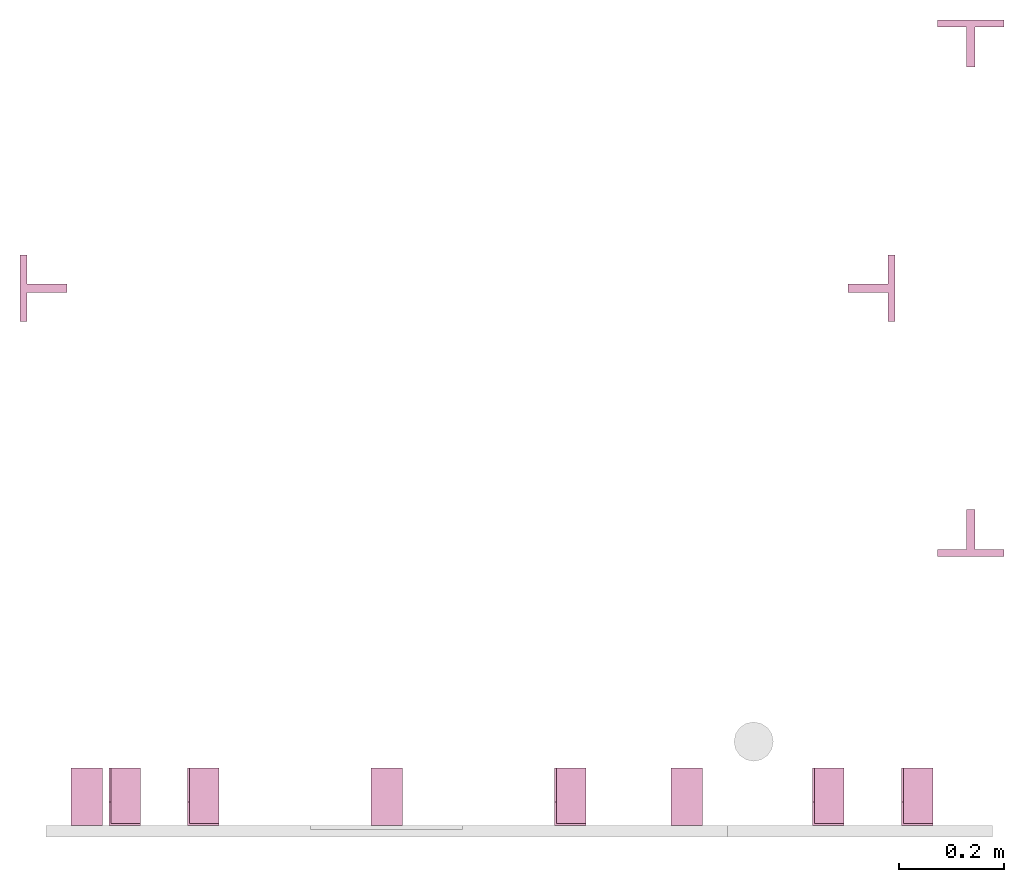
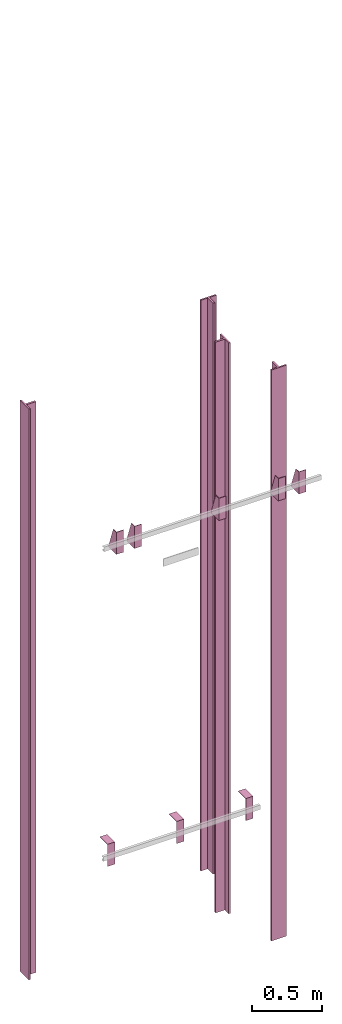
# One storey, part 3 of 3: 12 transport elements.
"""IFC4 building model written with IfcOpenShell, lengths in millimetres."""

from ifc_helpers import new_model, entity, si_unit, converted_unit, frame, origin_with_axes, place, context, subcontext, project, spatial, faceted_brep, element, save


model = new_model("IFC4")

# Units and contexts
context_of_model = context(None, 3, precision=0.01, world=origin_with_axes())
sub_context_1 = subcontext(context_of_model, None, None, "MODEL_VIEW")
sub_context_2 = subcontext(context_of_model, None, None, "MODEL_VIEW")
sub_context_3 = subcontext(context_of_model, None, None, "MODEL_VIEW")
sub_context_4 = subcontext(context_of_model, None, None, "MODEL_VIEW")
sub_context_5 = subcontext(context_of_model, None, None, "MODEL_VIEW")
sub_context_6 = subcontext(context_of_model, None, None, "MODEL_VIEW")
sub_context_7 = subcontext(context_of_model, None, None, "MODEL_VIEW")
sub_context_8 = subcontext(context_of_model, None, None, "MODEL_VIEW")
sub_context_9 = subcontext(context_of_model, None, None, "MODEL_VIEW")
sub_context_10 = subcontext(context_of_model, None, None, "MODEL_VIEW")
sub_context_11 = subcontext(context_of_model, None, None, "MODEL_VIEW")
sub_context_12 = subcontext(context_of_model, None, None, "MODEL_VIEW")
ifc_project = project(units=[converted_unit("PLANEANGLEUNIT", "degree", entity("IfcPlaneAngleMeasure", 0.017453292519943), si_unit("PLANEANGLEUNIT", "RADIAN"), dimensions=[0, 0, 0, 0, 0, 0, 0]), si_unit("LENGTHUNIT", "METRE", prefix="MILLI"), si_unit("MASSUNIT", "GRAM", prefix="KILO"), converted_unit("TIMEUNIT", "year", entity("IfcTimeMeasure", 31557600.0), si_unit("TIMEUNIT", "SECOND"), dimensions=[0, 0, 1, 0, 0, 0, 0]), si_unit("THERMODYNAMICTEMPERATUREUNIT", "DEGREE_CELSIUS"), si_unit("AREAUNIT", "SQUARE_METRE"), si_unit("FORCEUNIT", "NEWTON"), si_unit("VOLUMEUNIT", "CUBIC_METRE"), si_unit("PRESSUREUNIT", "PASCAL"), si_unit("SOLIDANGLEUNIT", "STERADIAN")], contexts=[context_of_model])

# Site, building, storey
site = spatial("IfcSite", under=ifc_project)
building = spatial("IfcBuilding", under=site, Name="Document")
placement = place(None, origin_with_axes())
storey_placement = place(placement, frame((0.0, 0.0, -14620.0), z_axis=(0.0, 0.0, 1.0), x_axis=(1.0, 0.0, 0.0)))
storey = spatial("IfcBuildingStorey", under=building, at=storey_placement, Name="P4", Elevation=-14620.0)

# Transport elements
transport_element_1_placement = place(storey_placement, frame((1879.0, 558.5, 733.0), z_axis=(0.0, -1.0, 0.0), x_axis=(0.0, 0.0, -1.0)))
element("IfcTransportElement", 1, at=transport_element_1_placement, inside=storey, ObjectType="Guide Rail", PredefinedType="ELEVATOR", context=sub_context_1, shape_type="Brep", body=[
    faceted_brep([(2347.5, -63.5, 45.0), (2347.5, 63.5, 45.0), (2347.5, 63.5, 44.0), (2347.5, -63.5, 44.0), (2500.0, -63.5, 45.0), (2500.0, -63.5, 44.0), (2500.0, 63.5, 44.0), (2500.0, 63.5, 45.0)], [[[0, 1, 2, 3]], [[4, 5, 6, 7]], [[0, 3, 5, 4]], [[3, 2, 6, 5]], [[2, 1, 7, 6]], [[1, 0, 4, 7]]]),
    faceted_brep([(-2500.0, -63.5, 45.0), (-2500.0, 63.5, 45.0), (-2500.0, 63.5, 44.0), (-2500.0, -63.5, 44.0), (-2347.5, -63.5, 45.0), (-2347.5, -63.5, 44.0), (-2347.5, 63.5, 44.0), (-2347.5, 63.5, 45.0)], [[[0, 1, 2, 3]], [[4, 5, 6, 7]], [[0, 3, 5, 4]], [[3, 2, 6, 5]], [[2, 1, 7, 6]], [[1, 0, 4, 7]]]),
    faceted_brep([(-2500.0, -63.5, 44.5), (-2500.0, -63.5, 31.79998779296875), (2500.0, -63.5, 31.79998779296875), (2500.0, -63.5, 44.5), (-2500.0, -7.93994140625, 31.79998779296875), (-2500.0, -7.93994140625, -44.5), (2500.0, -7.93994140625, -44.5), (2500.0, -7.93994140625, 31.79998779296875), (2500.0, 7.93994140625, -44.5), (-2500.0, 7.93994140625, -44.5), (-2500.0, 7.93994140625, 31.79998779296875), (2500.0, 7.93994140625, 31.79998779296875), (2500.0, 63.5, 31.79998779296875), (-2500.0, 63.5, 31.79998779296875), (-2500.0, 63.5, 44.5), (2500.0, 63.5, 44.5)], [[[0, 1, 2, 3]], [[4, 5, 6, 7]], [[8, 9, 10, 11]], [[12, 13, 14, 15]], [[15, 14, 0, 3]], [[1, 4, 7, 2]], [[10, 13, 12, 11]], [[5, 9, 8, 6]], [[2, 7, 6, 8, 11, 12, 15, 3]], [[14, 13, 10, 9, 5, 4, 1, 0]]]),
])
transport_element_2_placement = place(storey_placement, frame((1879.0, 1491.5, 733.0), z_axis=(0.0, 1.0, 0.0), x_axis=(0.0, 0.0, 1.0)))
element("IfcTransportElement", 2, at=transport_element_2_placement, inside=storey, ObjectType="Guide Rail", PredefinedType="ELEVATOR", context=sub_context_2, shape_type="Brep", body=[
    faceted_brep([(-2500.0, -63.5, 45.0), (-2500.0, 63.5, 45.0), (-2500.0, 63.5, 44.0), (-2500.0, -63.5, 44.0), (-2347.5, -63.5, 45.0), (-2347.5, -63.5, 44.0), (-2347.5, 63.5, 44.0), (-2347.5, 63.5, 45.0)], [[[0, 1, 2, 3]], [[4, 5, 6, 7]], [[0, 3, 5, 4]], [[3, 2, 6, 5]], [[2, 1, 7, 6]], [[1, 0, 4, 7]]]),
    faceted_brep([(2347.5, -63.5, 45.0), (2347.5, 63.5, 45.0), (2347.5, 63.5, 44.0), (2347.5, -63.5, 44.0), (2500.0, -63.5, 45.0), (2500.0, -63.5, 44.0), (2500.0, 63.5, 44.0), (2500.0, 63.5, 45.0)], [[[0, 1, 2, 3]], [[4, 5, 6, 7]], [[0, 3, 5, 4]], [[3, 2, 6, 5]], [[2, 1, 7, 6]], [[1, 0, 4, 7]]]),
    faceted_brep([(2500.0, -63.5, 31.800048828125), (2500.0, -63.5, 44.5), (-2500.0, -63.5, 44.5), (-2500.0, -63.5, 31.800048828125), (2500.0, -7.93994140625, -44.5), (2500.0, -7.93994140625, 31.800048828125), (-2500.0, -7.93994140625, 31.800048828125), (-2500.0, -7.93994140625, -44.5), (-2500.0, 7.93994140625, 31.800048828125), (2500.0, 7.93994140625, 31.800048828125), (2500.0, 7.93994140625, -44.5), (-2500.0, 7.93994140625, -44.5), (-2500.0, 63.5, 44.5), (2500.0, 63.5, 44.5), (2500.0, 63.5, 31.800048828125), (-2500.0, 63.5, 31.800048828125)], [[[0, 1, 2, 3]], [[4, 5, 6, 7]], [[8, 9, 10, 11]], [[12, 13, 14, 15]], [[6, 5, 0, 3]], [[1, 13, 12, 2]], [[11, 10, 4, 7]], [[9, 8, 15, 14]], [[2, 12, 15, 8, 11, 7, 6, 3]], [[5, 4, 10, 9, 14, 13, 1, 0]]]),
])
transport_element_3_placement = place(storey_placement, frame((110.5, 1025.0, 733.0), z_axis=(-1.0, 0.0, 0.0), x_axis=(0.0, 0.0, -1.0)))
element("IfcTransportElement", 3, at=transport_element_3_placement, inside=storey, ObjectType="Guide Rail", PredefinedType="ELEVATOR", context=sub_context_3, shape_type="Brep", body=[
    faceted_brep([(-2500.0, -63.5, 45.0), (-2500.0, 63.5, 45.0), (-2500.0, 63.5, 44.0), (-2500.0, -63.5, 44.0), (-2347.5, -63.5, 45.0), (-2347.5, -63.5, 44.0), (-2347.5, 63.5, 44.0), (-2347.5, 63.5, 45.0)], [[[0, 1, 2, 3]], [[4, 5, 6, 7]], [[0, 3, 5, 4]], [[3, 2, 6, 5]], [[2, 1, 7, 6]], [[1, 0, 4, 7]]]),
    faceted_brep([(2347.5, -63.5, 45.0), (2347.5, 63.5, 45.0), (2347.5, 63.5, 44.0), (2347.5, -63.5, 44.0), (2500.0, -63.5, 45.0), (2500.0, -63.5, 44.0), (2500.0, 63.5, 44.0), (2500.0, 63.5, 45.0)], [[[0, 1, 2, 3]], [[4, 5, 6, 7]], [[0, 3, 5, 4]], [[3, 2, 6, 5]], [[2, 1, 7, 6]], [[1, 0, 4, 7]]]),
    faceted_brep([(-2500.0, 63.5, 44.5), (-2500.0, -63.5, 44.5), (2500.0, -63.5, 44.5), (2500.0, 63.5, 44.5), (2500.0, 7.94000244140625, 31.800003051757812), (-2500.0, 7.94000244140625, 31.800003051757812), (-2500.0, 63.5, 31.79998779296875), (2500.0, 63.5, 31.79998779296875), (2500.0, -63.5, 31.79998779296875), (-2500.0, -63.5, 31.79998779296875), (-2500.0, -7.93994140625, 31.79998779296875), (2500.0, -7.93994140625, 31.79998779296875), (2500.0, -7.93994140625, -44.5), (-2500.0, -7.93994140625, -44.5), (-2500.0, 7.94000244140625, -44.5), (2500.0, 7.94000244140625, -44.5)], [[[0, 1, 2, 3]], [[4, 5, 6, 7]], [[8, 9, 10, 11]], [[12, 13, 14, 15]], [[7, 6, 0, 3]], [[15, 14, 5, 4]], [[10, 13, 12, 11]], [[1, 9, 8, 2]], [[2, 8, 11, 12, 15, 4, 7, 3]], [[6, 5, 14, 13, 10, 9, 1, 0]]]),
])
transport_element_4_placement = place(storey_placement, frame((1689.5, 1025.0, 733.0), z_axis=(1.0, 0.0, 0.0), x_axis=(0.0, 0.0, 1.0)))
element("IfcTransportElement", 4, at=transport_element_4_placement, inside=storey, ObjectType="Guide Rail", PredefinedType="ELEVATOR", context=sub_context_4, shape_type="Brep", body=[
    faceted_brep([(2347.5, -63.5, 45.0), (2347.5, 63.5, 45.0), (2347.5, 63.5, 44.0), (2347.5, -63.5, 44.0), (2500.0, -63.5, 45.0), (2500.0, -63.5, 44.0), (2500.0, 63.5, 44.0), (2500.0, 63.5, 45.0)], [[[0, 1, 2, 3]], [[4, 5, 6, 7]], [[0, 3, 5, 4]], [[3, 2, 6, 5]], [[2, 1, 7, 6]], [[1, 0, 4, 7]]]),
    faceted_brep([(-2500.0, -63.5, 45.0), (-2500.0, 63.5, 45.0), (-2500.0, 63.5, 44.0), (-2500.0, -63.5, 44.0), (-2347.5, -63.5, 45.0), (-2347.5, -63.5, 44.0), (-2347.5, 63.5, 44.0), (-2347.5, 63.5, 45.0)], [[[0, 1, 2, 3]], [[4, 5, 6, 7]], [[0, 3, 5, 4]], [[3, 2, 6, 5]], [[2, 1, 7, 6]], [[1, 0, 4, 7]]]),
    faceted_brep([(2500.0, 7.94000244140625, -44.5), (2500.0, -7.93994140625, -44.5), (-2500.0, -7.93994140625, -44.5), (-2500.0, 7.94000244140625, -44.5), (2500.0, 63.5, 31.800048828125), (2500.0, 7.94000244140625, 31.800048828125), (-2500.0, 7.94000244140625, 31.800048828125), (-2500.0, 63.5, 31.800048828125), (-2500.0, -63.5, 44.5), (2500.0, -63.5, 44.5), (2500.0, 63.5, 44.5), (-2500.0, 63.5, 44.5), (2500.0, -7.93994140625, 31.800048828125), (2500.0, -63.5, 31.800048828125), (-2500.0, -63.5, 31.800048828125), (-2500.0, -7.93994140625, 31.800048828125)], [[[0, 1, 2, 3]], [[4, 5, 6, 7]], [[8, 9, 10, 11]], [[12, 13, 14, 15]], [[6, 5, 0, 3]], [[1, 12, 15, 2]], [[11, 10, 4, 7]], [[13, 9, 8, 14]], [[2, 15, 14, 8, 11, 7, 6, 3]], [[5, 4, 10, 9, 13, 12, 1, 0]]]),
])
transport_element_5_placement = place(storey_placement, frame((265.0, 0.0, 2580.0), z_axis=(0.0, 0.0, 1.0), x_axis=(1.0, 0.0, 0.0)))
element("IfcTransportElement", 5, at=transport_element_5_placement, inside=storey, PredefinedType="ELEVATOR", context=sub_context_5, shape_type="Brep", body=[
    faceted_brep([(-30.0, 0.0, -97.0), (-30.0, 0.0, 97.0), (-30.0, 4.0, 97.0), (-30.0, 4.0, -93.0), (-30.0, 110.0, -93.0), (-30.0, 110.0, -97.0), (30.0, 110.0, -97.0), (30.0, 110.0, -93.0), (30.0, 4.0, -93.0), (30.0, 4.0, 97.0), (30.0, 0.0, 97.0), (30.0, 0.0, -97.0)], [[[0, 1, 2, 3, 4, 5]], [[6, 7, 8, 9, 10, 11]], [[11, 10, 1, 0]], [[2, 9, 8, 3]], [[4, 7, 6, 5]], [[5, 6, 11, 0]], [[8, 7, 4, 3]], [[10, 9, 2, 1]]]),
    faceted_brep([(-30.0, 4.0, -93.0), (-30.0, 4.0, 97.0), (-30.0, 45.0, 97.0), (-30.0, 110.0, -82.0), (-30.0, 110.0, -93.0), (-26.0, 4.0, -93.0), (-26.0, 110.0, -93.0), (-26.0, 110.0, -82.0), (-26.0, 45.0, 97.0), (-26.0, 4.0, 97.0)], [[[0, 1, 2, 3, 4]], [[5, 6, 7, 8, 9]], [[5, 0, 4, 6]], [[6, 4, 3, 7]], [[7, 3, 2, 8]], [[8, 2, 1, 9]], [[9, 1, 0, 5]]]),
])
transport_element_6_placement = place(storey_placement, frame((415.0, 0.0, 2580.0), z_axis=(0.0, 0.0, 1.0), x_axis=(1.0, 0.0, 0.0)))
element("IfcTransportElement", 6, at=transport_element_6_placement, inside=storey, PredefinedType="ELEVATOR", context=sub_context_6, shape_type="Brep", body=[
    faceted_brep([(-30.0, 0.0, -97.0), (-30.0, 0.0, 97.0), (-30.0, 4.0, 97.0), (-30.0, 4.0, -93.0), (-30.0, 110.0, -93.0), (-30.0, 110.0, -97.0), (30.0, 110.0, -97.0), (30.0, 110.0, -93.0), (30.0, 4.0, -93.0), (30.0, 4.0, 97.0), (30.0, 0.0, 97.0), (30.0, 0.0, -97.0)], [[[0, 1, 2, 3, 4, 5]], [[6, 7, 8, 9, 10, 11]], [[11, 10, 1, 0]], [[2, 9, 8, 3]], [[4, 7, 6, 5]], [[5, 6, 11, 0]], [[8, 7, 4, 3]], [[10, 9, 2, 1]]]),
    faceted_brep([(-30.0, 4.0, -93.0), (-30.0, 4.0, 97.0), (-30.0, 45.0, 97.0), (-30.0, 110.0, -82.0), (-30.0, 110.0, -93.0), (-26.0, 4.0, -93.0), (-26.0, 110.0, -93.0), (-26.0, 110.0, -82.0), (-26.0, 45.0, 97.0), (-26.0, 4.0, 97.0)], [[[0, 1, 2, 3, 4]], [[5, 6, 7, 8, 9]], [[5, 0, 4, 6]], [[6, 4, 3, 7]], [[7, 3, 2, 8]], [[8, 2, 1, 9]], [[9, 1, 0, 5]]]),
])
transport_element_7_placement = place(storey_placement, frame((1115.0, 0.0, 2580.0), z_axis=(0.0, 0.0, 1.0), x_axis=(1.0, 0.0, 0.0)))
element("IfcTransportElement", 7, at=transport_element_7_placement, inside=storey, PredefinedType="ELEVATOR", context=sub_context_7, shape_type="Brep", body=[
    faceted_brep([(-30.0, 0.0, -97.0), (-30.0, 0.0, 97.0), (-30.0, 4.0, 97.0), (-30.0, 4.0, -93.0), (-30.0, 110.0, -93.0), (-30.0, 110.0, -97.0), (30.0, 110.0, -97.0), (30.0, 110.0, -93.0), (30.0, 4.0, -93.0), (30.0, 4.0, 97.0), (30.0, 0.0, 97.0), (30.0, 0.0, -97.0)], [[[0, 1, 2, 3, 4, 5]], [[6, 7, 8, 9, 10, 11]], [[11, 10, 1, 0]], [[2, 9, 8, 3]], [[4, 7, 6, 5]], [[5, 6, 11, 0]], [[8, 7, 4, 3]], [[10, 9, 2, 1]]]),
    faceted_brep([(-30.0, 4.0, -93.0), (-30.0, 4.0, 97.0), (-30.0, 45.0, 97.0), (-30.0, 110.0, -82.0), (-30.0, 110.0, -93.0), (-26.0, 4.0, -93.0), (-26.0, 110.0, -93.0), (-26.0, 110.0, -82.0), (-26.0, 45.0, 97.0), (-26.0, 4.0, 97.0)], [[[0, 1, 2, 3, 4]], [[5, 6, 7, 8, 9]], [[5, 0, 4, 6]], [[6, 4, 3, 7]], [[7, 3, 2, 8]], [[8, 2, 1, 9]], [[9, 1, 0, 5]]]),
])
transport_element_8_placement = place(storey_placement, frame((1607.0, 0.0, 2580.0), z_axis=(0.0, 0.0, 1.0), x_axis=(1.0, 0.0, 0.0)))
element("IfcTransportElement", 8, at=transport_element_8_placement, inside=storey, PredefinedType="ELEVATOR", context=sub_context_8, shape_type="Brep", body=[
    faceted_brep([(-30.0, 0.0, -97.0), (-30.0, 0.0, 97.0), (-30.0, 4.0, 97.0), (-30.0, 4.0, -93.0), (-30.0, 110.0, -93.0), (-30.0, 110.0, -97.0), (30.0, 110.0, -97.0), (30.0, 110.0, -93.0), (30.0, 4.0, -93.0), (30.0, 4.0, 97.0), (30.0, 0.0, 97.0), (30.0, 0.0, -97.0)], [[[0, 1, 2, 3, 4, 5]], [[6, 7, 8, 9, 10, 11]], [[11, 10, 1, 0]], [[2, 9, 8, 3]], [[4, 7, 6, 5]], [[5, 6, 11, 0]], [[8, 7, 4, 3]], [[10, 9, 2, 1]]]),
    faceted_brep([(-30.0, 4.0, -93.0), (-30.0, 4.0, 97.0), (-30.0, 45.0, 97.0), (-30.0, 110.0, -82.0), (-30.0, 110.0, -93.0), (-26.0, 4.0, -93.0), (-26.0, 110.0, -93.0), (-26.0, 110.0, -82.0), (-26.0, 45.0, 97.0), (-26.0, 4.0, 97.0)], [[[0, 1, 2, 3, 4]], [[5, 6, 7, 8, 9]], [[5, 0, 4, 6]], [[6, 4, 3, 7]], [[7, 3, 2, 8]], [[8, 2, 1, 9]], [[9, 1, 0, 5]]]),
])
transport_element_9_placement = place(storey_placement, frame((1777.0, 0.0, 2580.0), z_axis=(0.0, 0.0, 1.0), x_axis=(1.0, 0.0, 0.0)))
element("IfcTransportElement", 9, at=transport_element_9_placement, inside=storey, PredefinedType="ELEVATOR", context=sub_context_9, shape_type="Brep", body=[
    faceted_brep([(-30.0, 0.0, -97.0), (-30.0, 0.0, 97.0), (-30.0, 4.0, 97.0), (-30.0, 4.0, -93.0), (-30.0, 110.0, -93.0), (-30.0, 110.0, -97.0), (30.0, 110.0, -97.0), (30.0, 110.0, -93.0), (30.0, 4.0, -93.0), (30.0, 4.0, 97.0), (30.0, 0.0, 97.0), (30.0, 0.0, -97.0)], [[[0, 1, 2, 3, 4, 5]], [[6, 7, 8, 9, 10, 11]], [[11, 10, 1, 0]], [[2, 9, 8, 3]], [[4, 7, 6, 5]], [[5, 6, 11, 0]], [[8, 7, 4, 3]], [[10, 9, 2, 1]]]),
    faceted_brep([(-30.0, 4.0, -93.0), (-30.0, 4.0, 97.0), (-30.0, 45.0, 97.0), (-30.0, 110.0, -82.0), (-30.0, 110.0, -93.0), (-26.0, 4.0, -93.0), (-26.0, 110.0, -93.0), (-26.0, 110.0, -82.0), (-26.0, 45.0, 97.0), (-26.0, 4.0, 97.0)], [[[0, 1, 2, 3, 4]], [[5, 6, 7, 8, 9]], [[5, 0, 4, 6]], [[6, 4, 3, 7]], [[7, 3, 2, 8]], [[8, 2, 1, 9]], [[9, 1, 0, 5]]]),
])
transport_element_10_placement = place(storey_placement, frame((1337.5, 0.0, -30.0), z_axis=(0.0, 0.0, -1.0), x_axis=(-1.0, 0.0, 0.0)))
element("IfcTransportElement", 10, at=transport_element_10_placement, inside=storey, PredefinedType="ELEVATOR", context=sub_context_10, shape_type="Brep", body=[
    faceted_brep([(30.0, 0.0, 0.0), (30.0, 110.0, 0.0), (30.0, 110.0, 4.0), (30.0, 4.0, 4.0), (30.0, 4.0, 194.0), (30.0, 0.0, 194.0), (-30.0, 4.0, 194.0), (-30.0, 4.0, 4.0), (-30.0, 110.0, 4.0), (-30.0, 110.0, 0.0), (-30.0, 0.0, 0.0), (-30.0, 0.0, 194.0)], [[[0, 1, 2, 3, 4, 5]], [[6, 7, 8, 9, 10, 11]], [[11, 10, 0, 5]], [[3, 7, 6, 4]], [[1, 9, 8, 2]], [[4, 6, 11, 5]], [[10, 9, 1, 0]], [[2, 8, 7, 3]]]),
    faceted_brep([(-30.0, 4.0, 4.0), (-30.0, 4.0, 194.0), (-30.0, 45.0, 194.0), (-30.0, 110.0, 15.0), (-30.0, 110.0, 4.0), (-26.0, 4.0, 4.0), (-26.0, 110.0, 4.0), (-26.0, 110.0, 15.0), (-26.0, 45.0, 194.0), (-26.0, 4.0, 194.0)], [[[0, 1, 2, 3, 4]], [[5, 6, 7, 8, 9]], [[5, 0, 4, 6]], [[6, 4, 3, 7]], [[7, 3, 2, 8]], [[8, 2, 1, 9]], [[9, 1, 0, 5]]]),
])
transport_element_11_placement = place(storey_placement, frame((765.0, 0.0, -30.0), z_axis=(0.0, 0.0, -1.0), x_axis=(-1.0, 0.0, 0.0)))
element("IfcTransportElement", 11, at=transport_element_11_placement, inside=storey, PredefinedType="ELEVATOR", context=sub_context_11, shape_type="Brep", body=[
    faceted_brep([(30.0, 0.0, 0.0), (30.0, 110.0, 0.0), (30.0, 110.0, 4.0), (30.0, 4.0, 4.0), (30.0, 4.0, 194.0), (30.0, 0.0, 194.0), (-30.0, 4.0, 194.0), (-30.0, 4.0, 4.0), (-30.0, 110.0, 4.0), (-30.0, 110.0, 0.0), (-30.0, 0.0, 0.0), (-30.0, 0.0, 194.0)], [[[0, 1, 2, 3, 4, 5]], [[6, 7, 8, 9, 10, 11]], [[11, 10, 0, 5]], [[3, 7, 6, 4]], [[1, 9, 8, 2]], [[4, 6, 11, 5]], [[10, 9, 1, 0]], [[2, 8, 7, 3]]]),
    faceted_brep([(-30.0, 4.0, 4.0), (-30.0, 4.0, 194.0), (-30.0, 45.0, 194.0), (-30.0, 110.0, 15.0), (-30.0, 110.0, 4.0), (-26.0, 4.0, 4.0), (-26.0, 110.0, 4.0), (-26.0, 110.0, 15.0), (-26.0, 45.0, 194.0), (-26.0, 4.0, 194.0)], [[[0, 1, 2, 3, 4]], [[5, 6, 7, 8, 9]], [[5, 0, 4, 6]], [[6, 4, 3, 7]], [[7, 3, 2, 8]], [[8, 2, 1, 9]], [[9, 1, 0, 5]]]),
])
transport_element_12_placement = place(storey_placement, frame((192.5, 0.0, -30.0), z_axis=(0.0, 0.0, -1.0), x_axis=(-1.0, 0.0, 0.0)))
element("IfcTransportElement", 12, at=transport_element_12_placement, inside=storey, PredefinedType="ELEVATOR", context=sub_context_12, shape_type="Brep", body=[
    faceted_brep([(-30.0, 4.0, 4.0), (-30.0, 4.0, 194.0), (-30.0, 45.0, 194.0), (-30.0, 110.0, 15.0), (-30.0, 110.0, 4.0), (-26.0, 4.0, 4.0), (-26.0, 110.0, 4.0), (-26.0, 110.0, 15.0), (-26.0, 45.0, 194.0), (-26.0, 4.0, 194.0)], [[[0, 1, 2, 3, 4]], [[5, 6, 7, 8, 9]], [[5, 0, 4, 6]], [[6, 4, 3, 7]], [[7, 3, 2, 8]], [[8, 2, 1, 9]], [[9, 1, 0, 5]]]),
    faceted_brep([(30.0, 0.0, 0.0), (30.0, 110.0, 0.0), (30.0, 110.0, 4.0), (30.0, 4.0, 4.0), (30.0, 4.0, 194.0), (30.0, 0.0, 194.0), (-30.0, 4.0, 194.0), (-30.0, 4.0, 4.0), (-30.0, 110.0, 4.0), (-30.0, 110.0, 0.0), (-30.0, 0.0, 0.0), (-30.0, 0.0, 194.0)], [[[0, 1, 2, 3, 4, 5]], [[6, 7, 8, 9, 10, 11]], [[11, 10, 0, 5]], [[3, 7, 6, 4]], [[1, 9, 8, 2]], [[4, 6, 11, 5]], [[10, 9, 1, 0]], [[2, 8, 7, 3]]]),
])

save(model, "model.ifc")
